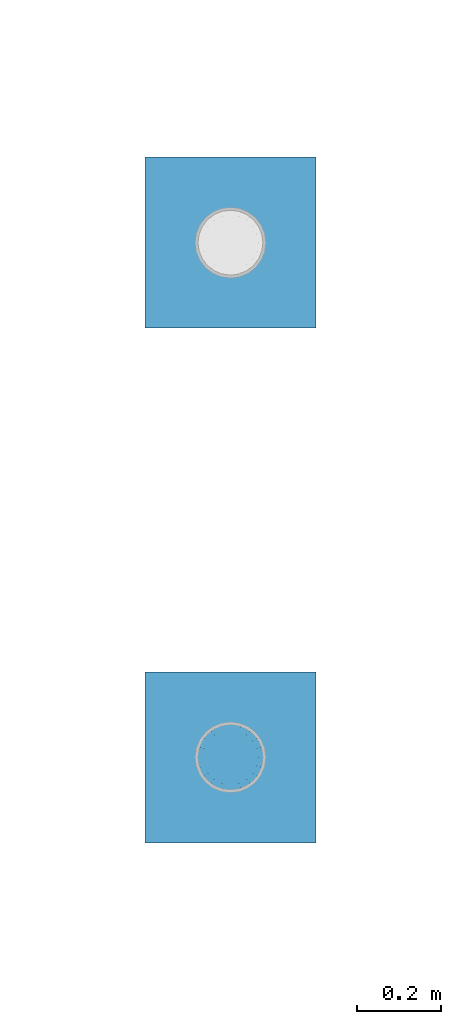
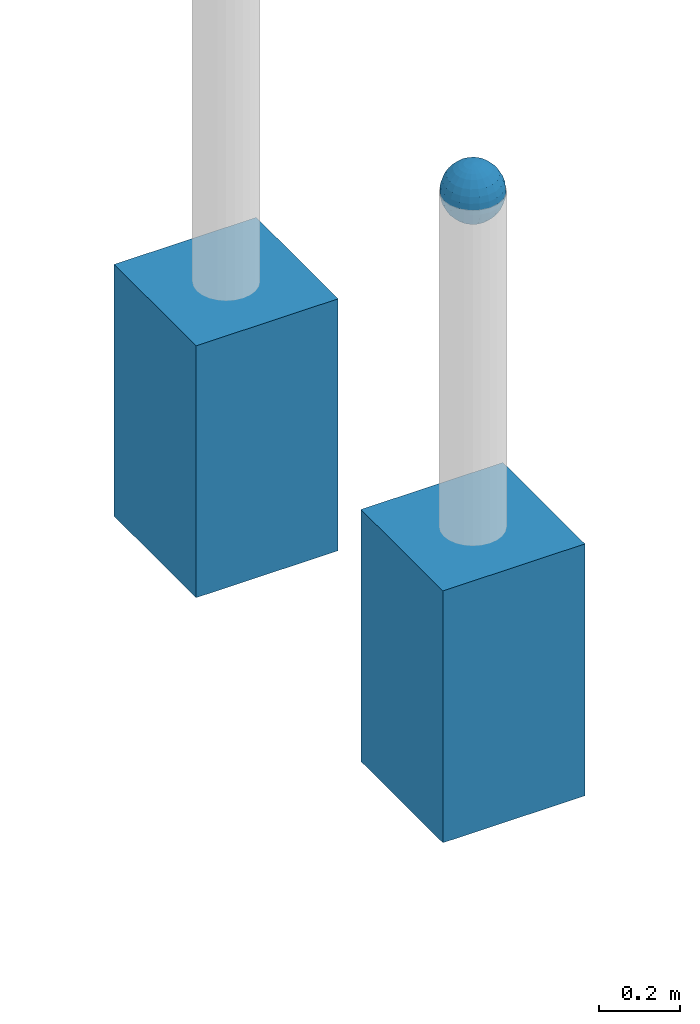
# One storey, part 1612 of 3843: 3 columns, 3 elements without a shape of their own.
"""IFC2X3 building model written with IfcOpenShell, lengths in millimetres."""

from ifc_helpers import new_model, si_unit, frame, origin_with_axes, place, context, subcontext, project, spatial, faceted_brep, material, type_object, element, aggregate, save


model = new_model("IFC2X3")

# Units and contexts
model_context = context("Model", 3, precision=1e-05, world=origin_with_axes())
body_context = subcontext(model_context, "Body", "Model", "MODEL_VIEW")
ifc_project = project(units=[si_unit("LENGTHUNIT", "METRE", prefix="MILLI"), si_unit("AREAUNIT", "SQUARE_METRE"), si_unit("VOLUMEUNIT", "CUBIC_METRE"), si_unit("MASSUNIT", "GRAM", prefix="KILO"), si_unit("TIMEUNIT", "SECOND"), si_unit("PLANEANGLEUNIT", "RADIAN"), si_unit("SOLIDANGLEUNIT", "STERADIAN"), si_unit("THERMODYNAMICTEMPERATUREUNIT", "DEGREE_CELSIUS"), si_unit("LUMINOUSINTENSITYUNIT", "LUMEN")], contexts=[model_context])

# Site, building, storey
site_placement = place(None, origin_with_axes())
site = spatial("IfcSite", under=ifc_project, at=site_placement, CompositionType="ELEMENT")
building_placement = place(site_placement, origin_with_axes())
building = spatial("IfcBuilding", under=site, at=building_placement, Name="Undefined", CompositionType="ELEMENT")
storey_placement = place(building_placement, origin_with_axes())
storey = spatial("IfcBuildingStorey", under=building, at=storey_placement, Name="Undefined", CompositionType="ELEMENT", Elevation=0.0)

# Assembly, column
assembly_1_placement = place(storey_placement, origin_with_axes())
assembly_1 = element("IfcElementAssembly", 1, at=assembly_1_placement, inside=storey, Name="CONC_COL.", AssemblyPlace="NOTDEFINED", PredefinedType="REINFORCEMENT_UNIT")
ifc_material_1 = material(Name="CONCRETE/3000")
column_type_1 = type_object("IfcColumnType", PredefinedType="NOTDEFINED")
column_1_placement = place(assembly_1_placement, frame((90265.7801817656, 12035.795690304, 29718.0), z_axis=(-1.0, 0.0, 0.0), x_axis=(0.0, 0.0, 1.0)))
column_1 = element("IfcColumn", 2, at=column_1_placement, type_object=column_type_1, material=ifc_material_1, Name="CONC_COL.", context=body_context, shape_type="Brep", body=[
    faceted_brep([(0.0, 203.199999999997, -203.200000000001), (0.0, 203.199999999997, 203.200000000001), (762.0, 203.199999999997, 203.200000000001), (762.0, 203.199999999997, -203.200000000001), (0.0, -203.199999999997, 203.200000000001), (762.0, -203.199999999997, 203.200000000001), (0.0, -203.199999999997, -203.200000000001), (762.0, -203.199999999997, -203.200000000001)], [[[0, 1, 2, 3]], [[1, 4, 5, 2]], [[4, 6, 7, 5]], [[6, 0, 3, 7]], [[5, 7, 3, 2]], [[6, 4, 1, 0]]]),
])
aggregate(assembly_1, [column_1])

assembly_2_placement = place(storey_placement, origin_with_axes())
assembly_2 = element("IfcElementAssembly", 3, at=assembly_2_placement, inside=storey, Name="CONC_COL.", AssemblyPlace="NOTDEFINED", PredefinedType="REINFORCEMENT_UNIT")
column_2_placement = place(assembly_2_placement, frame((90265.7801817656, 13258.3985345423, 29718.0), z_axis=(-1.0, 0.0, 0.0), x_axis=(0.0, 0.0, 1.0)))
column_2 = element("IfcColumn", 4, at=column_2_placement, type_object=column_type_1, material=ifc_material_1, Name="CONC_COL.", context=body_context, shape_type="Brep", body=[
    faceted_brep([(0.0, 203.199999999997, -203.200000000001), (0.0, 203.199999999997, 203.200000000001), (762.0, 203.199999999997, 203.200000000001), (762.0, 203.199999999997, -203.200000000001), (0.0, -203.199999999997, 203.200000000001), (762.0, -203.199999999997, 203.200000000001), (0.0, -203.199999999997, -203.200000000001), (762.0, -203.199999999997, -203.200000000001)], [[[0, 1, 2, 3]], [[1, 4, 5, 2]], [[4, 6, 7, 5]], [[6, 0, 3, 7]], [[5, 7, 3, 2]], [[6, 4, 1, 0]]]),
])
aggregate(assembly_2, [column_2])

assembly_3_placement = place(storey_placement, origin_with_axes())
assembly_3 = element("IfcElementAssembly", 5, at=assembly_3_placement, inside=storey, Name="CONC. FILL", AssemblyPlace="NOTDEFINED", PredefinedType="REINFORCEMENT_UNIT")
ifc_material_2 = material(Name="CONCRETE/1500")
column_type_2 = type_object("IfcColumnType", PredefinedType="NOTDEFINED")
column_3_placement = place(assembly_3_placement, frame((90265.7801817655, 12035.795690304, 31411.8625), z_axis=(-1.0, 0.0, 0.0), x_axis=(0.0, 0.0, 1.0)))
column_3 = element("IfcColumn", 6, at=column_3_placement, type_object=column_type_2, material=ifc_material_2, Name="CONC. FILL", context=body_context, shape_type="Brep", body=[
    faceted_brep([(0.0, 0.0, 2.0), (0.0, -0.619999999995343, 1.89999999999964), (3.36549999999988, -7.1422259999963, 21.9814139999999), (3.36549999999988, 0.0, 23.1139999999996), (0.0, -1.17999999999302, 1.6200000000008), (3.36549999999988, -13.5910319999966, 18.6992260000006), (0.0, -1.61999999999534, 1.18000000000029), (3.36549999999988, -18.699225999997, 13.5910320000003), (0.0, -1.89999999999418, 0.6200000000008), (3.36549999999988, -21.9814139999944, 7.14222599999994), (0.0, -2.0, 0.0), (3.36549999999988, -23.1140000000014, 0.0), (0.0, -1.89999999999418, -0.6200000000008), (3.36549999999988, -21.9814139999944, -7.14222599999994), (0.0, -1.61999999999534, -1.18000000000029), (3.36549999999988, -18.699225999997, -13.5910320000003), (0.0, -1.17999999999302, -1.6200000000008), (3.36549999999988, -13.5910319999966, -18.6992260000006), (0.0, -0.619999999995343, -1.89999999999964), (3.36549999999988, -7.1422259999963, -21.9814139999999), (0.0, 0.0, -2.0), (3.36549999999988, 0.0, -23.1139999999996), (0.0, 0.619999999995343, -1.89999999999964), (3.36549999999988, 7.1422259999963, -21.9814139999999), (0.0, 1.17999999999302, -1.6200000000008), (3.36549999999988, 13.5910319999966, -18.6992260000006), (0.0, 1.61999999999534, -1.18000000000029), (3.36549999999988, 18.699225999997, -13.5910320000003), (0.0, 1.89999999999418, -0.6200000000008), (3.36549999999988, 21.9814139999944, -7.14222599999994), (0.0, 2.0, 0.0), (3.36549999999988, 23.1140000000014, 0.0), (0.0, 1.89999999999418, 0.6200000000008), (3.36549999999988, 21.9814139999944, 7.14222599999994), (0.0, 1.61999999999534, 1.18000000000029), (3.36549999999988, 18.699225999997, 13.5910320000003), (0.0, 1.17999999999302, 1.6200000000008), (3.36549999999988, 13.5910319999966, 18.6992260000006), (0.0, 0.619999999995343, 1.89999999999964), (3.36549999999988, 7.1422259999963, 21.9814139999999), (8.41374999999971, -11.1214661999984, 34.2282018000005), (8.41374999999971, 0.0, 35.9917999999998), (8.41374999999971, -21.1631784000056, 29.1173662000001), (8.41374999999971, -29.1173661999928, 21.1631784000001), (8.41374999999971, -34.2282017999969, 11.1214662000002), (8.41374999999971, -35.9918000000034, 0.0), (8.41374999999971, -34.2282017999969, -11.1214662000002), (8.41374999999971, -29.1173661999928, -21.1631784000001), (8.41374999999971, -21.1631784000056, -29.1173662000001), (8.41374999999971, -11.1214661999984, -34.2282018000005), (8.41374999999971, 0.0, -35.9917999999998), (8.41374999999971, 11.1214661999984, -34.2282018000005), (8.41374999999971, 21.1631784000056, -29.1173662000001), (8.41374999999971, 29.1173661999928, -21.1631784000001), (8.41374999999971, 34.2282017999969, -11.1214662000002), (8.41374999999971, 35.9918000000034, 0.0), (8.41374999999971, 34.2282017999969, 11.1214662000002), (8.41374999999971, 29.1173661999928, 21.1631784000001), (8.41374999999971, 21.1631784000056, 29.1173662000001), (8.41374999999971, 11.1214661999984, 34.2282018000005), (16.8274999999994, -15.3047700000025, 47.1030300000002), (16.8274999999994, 0.0, 49.5300000000007), (16.8274999999994, -29.1236400000053, 40.0697700000001), (16.8274999999994, -40.0697700000019, 29.1236399999998), (16.8274999999994, -47.1030299999984, 15.3047700000006), (16.8274999999994, -49.5299999999988, 0.0), (16.8274999999994, -47.1030299999984, -15.3047700000006), (16.8274999999994, -40.0697700000019, -29.1236399999998), (16.8274999999994, -29.1236400000053, -40.0697700000001), (16.8274999999994, -15.3047700000025, -47.1030300000002), (16.8274999999994, 0.0, -49.5300000000007), (16.8274999999994, 15.3047700000025, -47.1030300000002), (16.8274999999994, 29.1236400000053, -40.0697700000001), (16.8274999999994, 40.0697700000019, -29.1236399999998), (16.8274999999994, 47.1030299999984, -15.3047700000006), (16.8274999999994, 49.5299999999988, 0.0), (16.8274999999994, 47.1030299999984, 15.3047700000006), (16.8274999999994, 40.0697700000019, 29.1236399999998), (16.8274999999994, 29.1236400000053, 40.0697700000001), (16.8274999999994, 15.3047700000025, 47.1030300000002), (33.6549999999988, -20.4063599999936, 62.8040400000009), (33.6549999999988, 0.0, 66.0400000000009), (33.6549999999988, -38.831520000007, 53.4263599999995), (33.6549999999988, -53.4263599999977, 38.8315199999997), (33.6549999999988, -62.8040400000027, 20.4063600000009), (33.6549999999988, -66.0399999999936, 0.0), (33.6549999999988, -62.8040400000027, -20.4063600000009), (33.6549999999988, -53.4263599999977, -38.8315199999997), (33.6549999999988, -38.831520000007, -53.4263599999995), (33.6549999999988, -20.4063599999936, -62.8040400000009), (33.6549999999988, 0.0, -66.0400000000009), (33.6549999999988, 20.4063599999936, -62.8040400000009), (33.6549999999988, 38.831520000007, -53.4263599999995), (33.6549999999988, 53.4263599999977, -38.8315199999997), (33.6549999999988, 62.8040400000027, -20.4063600000009), (33.6549999999988, 66.0399999999936, 0.0), (33.6549999999988, 62.8040400000027, 20.4063600000009), (33.6549999999988, 53.4263599999977, 38.8315199999997), (33.6549999999988, 38.831520000007, 53.4263599999995), (33.6549999999988, 20.4063599999936, 62.8040400000009), (50.4824999999983, -23.3907901500061, 71.9891308499991), (50.4824999999983, 0.0, 75.6983500000006), (50.4824999999983, -44.5106298000028, 61.23996515), (50.4824999999983, -61.2399651500018, 44.5106297999992), (50.4824999999983, -71.9891308499937, 23.3907901500006), (50.4824999999983, -75.698350000006, 0.0), (50.4824999999983, -71.9891308499937, -23.3907901500006), (50.4824999999983, -61.2399651500018, -44.5106297999992), (50.4824999999983, -44.5106298000028, -61.23996515), (50.4824999999983, -23.3907901500061, -71.9891308499991), (50.4824999999983, 0.0, -75.6983500000006), (50.4824999999983, 23.3907901500061, -71.9891308499991), (50.4824999999983, 44.5106298000028, -61.23996515), (50.4824999999983, 61.2399651500018, -44.5106297999992), (50.4824999999983, 71.9891308499937, -23.3907901500006), (50.4824999999983, 75.698350000006, 0.0), (50.4824999999983, 71.9891308499937, 23.3907901500006), (50.4824999999983, 61.2399651500018, 44.5106297999992), (50.4824999999983, 44.5106298000028, 61.23996515), (50.4824999999983, 23.3907901500061, 71.9891308499991), (67.3099999999977, -24.9977910000016, 76.9349490000004), (67.3099999999977, 0.0, 80.8989999999994), (67.3099999999977, -47.5686120000028, 65.4472910000004), (67.3099999999977, -65.447291000004, 47.5686119999991), (67.3099999999977, -76.9349490000022, 24.9977909999998), (67.3099999999977, -80.8990000000049, 0.0), (67.3099999999977, -76.9349490000022, -24.9977909999998), (67.3099999999977, -65.447291000004, -47.5686119999991), (67.3099999999977, -47.5686120000028, -65.4472910000004), (67.3099999999977, -24.9977910000016, -76.9349490000004), (67.3099999999977, 0.0, -80.8989999999994), (67.3099999999977, 24.9977910000016, -76.9349490000004), (67.3099999999977, 47.5686120000028, -65.4472910000004), (67.3099999999977, 65.447291000004, -47.5686119999991), (67.3099999999977, 76.9349490000022, -24.9977909999998), (67.3099999999977, 80.8990000000049, 0.0), (67.3099999999977, 76.9349490000022, 24.9977909999998), (67.3099999999977, 65.447291000004, 47.5686119999991), (67.3099999999977, 47.5686120000028, 65.4472910000004), (67.3099999999977, 24.9977910000016, 76.9349490000004), (84.1374999999935, -25.5079499999993, 78.5050499999998), (84.1374999999935, 0.0, 82.5499999999993), (84.1374999999935, -48.5393999999942, 66.7829500000007), (84.1374999999935, -66.7829499999934, 48.5393999999997), (84.1374999999935, -78.505050000007, 25.5079499999993), (84.1374999999935, -82.5500000000029, 0.0), (84.1374999999935, -78.505050000007, -25.5079499999993), (84.1374999999935, -66.7829499999934, -48.5393999999997), (84.1374999999935, -48.5393999999942, -66.7829500000007), (84.1374999999935, -25.5079499999993, -78.5050499999998), (84.1374999999935, 0.0, -82.5499999999993), (84.1374999999935, 25.5079499999993, -78.5050499999998), (84.1374999999935, 48.5393999999942, -66.7829500000007), (84.1374999999935, 66.7829499999934, -48.5393999999997), (84.1374999999935, 78.505050000007, -25.5079499999993), (84.1374999999935, 82.5500000000029, 0.0), (84.1374999999935, 78.505050000007, 25.5079499999993), (84.1374999999935, 66.7829499999934, 48.5393999999997), (84.1374999999935, 48.5393999999942, 66.7829500000007), (84.1374999999935, 25.5079499999993, 78.5050499999998), (100.964999999993, -24.9977910000016, 76.9349490000004), (100.964999999993, 0.0, 80.8989999999994), (100.964999999993, -47.5686120000028, 65.4472910000004), (100.964999999993, -65.447291000004, 47.5686119999991), (100.964999999993, -76.9349490000022, 24.9977909999998), (100.964999999993, -80.8990000000049, 0.0), (100.964999999993, -76.9349490000022, -24.9977909999998), (100.964999999993, -65.447291000004, -47.5686119999991), (100.964999999993, -47.5686120000028, -65.4472910000004), (100.964999999993, -24.9977910000016, -76.9349490000004), (100.964999999993, 0.0, -80.8989999999994), (100.964999999993, 24.9977910000016, -76.9349490000004), (100.964999999993, 47.5686120000028, -65.4472910000004), (100.964999999993, 65.447291000004, -47.5686119999991), (100.964999999993, 76.9349490000022, -24.9977909999998), (100.964999999993, 80.8990000000049, 0.0), (100.964999999993, 76.9349490000022, 24.9977909999998), (100.964999999993, 65.447291000004, 47.5686119999991), (100.964999999993, 47.5686120000028, 65.4472910000004), (100.964999999993, 24.9977910000016, 76.9349490000004), (117.792499999992, -23.3907901500061, 71.9891308499991), (117.792499999992, 0.0, 75.6983500000006), (117.792499999992, -44.5106298000028, 61.23996515), (117.792499999992, -61.2399651500018, 44.5106297999992), (117.792499999992, -71.9891308499937, 23.3907901500006), (117.792499999992, -75.698350000006, 0.0), (117.792499999992, -71.9891308499937, -23.3907901500006), (117.792499999992, -61.2399651500018, -44.5106297999992), (117.792499999992, -44.5106298000028, -61.23996515), (117.792499999992, -23.3907901500061, -71.9891308499991), (117.792499999992, 0.0, -75.6983500000006), (117.792499999992, 23.3907901500061, -71.9891308499991), (117.792499999992, 44.5106298000028, -61.23996515), (117.792499999992, 61.2399651500018, -44.5106297999992), (117.792499999992, 71.9891308499937, -23.3907901500006), (117.792499999992, 75.698350000006, 0.0), (117.792499999992, 71.9891308499937, 23.3907901500006), (117.792499999992, 61.2399651500018, 44.5106297999992), (117.792499999992, 44.5106298000028, 61.23996515), (117.792499999992, 23.3907901500061, 71.9891308499991), (134.619999999992, -20.4063599999936, 62.8040400000009), (134.619999999992, 0.0, 66.0400000000009), (134.619999999992, -38.831520000007, 53.4263599999995), (134.619999999992, -53.4263599999977, 38.8315199999997), (134.619999999992, -62.8040400000027, 20.4063600000009), (134.619999999992, -66.0399999999936, 0.0), (134.619999999992, -62.8040400000027, -20.4063600000009), (134.619999999992, -53.4263599999977, -38.8315199999997), (134.619999999992, -38.831520000007, -53.4263599999995), (134.619999999992, -20.4063599999936, -62.8040400000009), (134.619999999992, 0.0, -66.0400000000009), (134.619999999992, 20.4063599999936, -62.8040400000009), (134.619999999992, 38.831520000007, -53.4263599999995), (134.619999999992, 53.4263599999977, -38.8315199999997), (134.619999999992, 62.8040400000027, -20.4063600000009), (134.619999999992, 66.0399999999936, 0.0), (134.619999999992, 62.8040400000027, 20.4063600000009), (134.619999999992, 53.4263599999977, 38.8315199999997), (134.619999999992, 38.831520000007, 53.4263599999995), (134.619999999992, 20.4063599999936, 62.8040400000009), (151.447499999991, -15.3047700000025, 47.1030300000002), (151.447499999991, 0.0, 49.5300000000007), (151.447499999991, -29.1236400000053, 40.0697700000001), (151.447499999991, -40.0697700000019, 29.1236399999998), (151.447499999991, -47.1030299999984, 15.3047700000006), (151.447499999991, -49.5299999999988, 0.0), (151.447499999991, -47.1030299999984, -15.3047700000006), (151.447499999991, -40.0697700000019, -29.1236399999998), (151.447499999991, -29.1236400000053, -40.0697700000001), (151.447499999991, -15.3047700000025, -47.1030300000002), (151.447499999991, 0.0, -49.5300000000007), (151.447499999991, 15.3047700000025, -47.1030300000002), (151.447499999991, 29.1236400000053, -40.0697700000001), (151.447499999991, 40.0697700000019, -29.1236399999998), (151.447499999991, 47.1030299999984, -15.3047700000006), (151.447499999991, 49.5299999999988, 0.0), (151.447499999991, 47.1030299999984, 15.3047700000006), (151.447499999991, 40.0697700000019, 29.1236399999998), (151.447499999991, 29.1236400000053, 40.0697700000001), (151.447499999991, 15.3047700000025, 47.1030300000002), (159.861249999991, -11.1214661999984, 34.2282018000005), (159.861249999991, 0.0, 35.9917999999998), (159.861249999991, -21.1631784000056, 29.1173662000001), (159.861249999991, -29.1173661999928, 21.1631784000001), (159.861249999991, -34.2282017999969, 11.1214662000002), (159.861249999991, -35.9918000000034, 0.0), (159.861249999991, -34.2282017999969, -11.1214662000002), (159.861249999991, -29.1173661999928, -21.1631784000001), (159.861249999991, -21.1631784000056, -29.1173662000001), (159.861249999991, -11.1214661999984, -34.2282018000005), (159.861249999991, 0.0, -35.9917999999998), (159.861249999991, 11.1214661999984, -34.2282018000005), (159.861249999991, 21.1631784000056, -29.1173662000001), (159.861249999991, 29.1173661999928, -21.1631784000001), (159.861249999991, 34.2282017999969, -11.1214662000002), (159.861249999991, 35.9918000000034, 0.0), (159.861249999991, 34.2282017999969, 11.1214662000002), (159.861249999991, 29.1173661999928, 21.1631784000001), (159.861249999991, 21.1631784000056, 29.1173662000001), (159.861249999991, 11.1214661999984, 34.2282018000005), (164.909499999991, -7.1422259999963, 21.9814139999999), (164.909499999991, 0.0, 23.1139999999996), (164.909499999991, -13.5910319999966, 18.6992260000006), (164.909499999991, -18.699225999997, 13.5910320000003), (164.909499999991, -21.9814139999944, 7.14222599999994), (164.909499999991, -23.1140000000014, 0.0), (164.909499999991, -21.9814139999944, -7.14222599999994), (164.909499999991, -18.699225999997, -13.5910320000003), (164.909499999991, -13.5910319999966, -18.6992260000006), (164.909499999991, -7.1422259999963, -21.9814139999999), (164.909499999991, 0.0, -23.1139999999996), (164.909499999991, 7.1422259999963, -21.9814139999999), (164.909499999991, 13.5910319999966, -18.6992260000006), (164.909499999991, 18.699225999997, -13.5910320000003), (164.909499999991, 21.9814139999944, -7.14222599999994), (164.909499999991, 23.1140000000014, 0.0), (164.909499999991, 21.9814139999944, 7.14222599999994), (164.909499999991, 18.699225999997, 13.5910320000003), (164.909499999991, 13.5910319999966, 18.6992260000006), (164.909499999991, 7.1422259999963, 21.9814139999999), (168.274999999991, -0.619999999995343, 1.89999999999964), (168.274999999991, 0.0, 2.0), (168.274999999991, -1.17999999999302, 1.6200000000008), (168.274999999991, -1.61999999999534, 1.18000000000029), (168.274999999991, -1.89999999999418, 0.6200000000008), (168.274999999991, -2.0, 0.0), (168.274999999991, -1.89999999999418, -0.6200000000008), (168.274999999991, -1.61999999999534, -1.18000000000029), (168.274999999991, -1.17999999999302, -1.6200000000008), (168.274999999991, -0.619999999995343, -1.89999999999964), (168.274999999991, 0.0, -2.0), (168.274999999991, 0.619999999995343, -1.89999999999964), (168.274999999991, 1.17999999999302, -1.6200000000008), (168.274999999991, 1.61999999999534, -1.18000000000029), (168.274999999991, 1.89999999999418, -0.6200000000008), (168.274999999991, 2.0, 0.0), (168.274999999991, 1.89999999999418, 0.6200000000008), (168.274999999991, 1.61999999999534, 1.18000000000029), (168.274999999991, 1.17999999999302, 1.6200000000008), (168.274999999991, 0.619999999995343, 1.89999999999964)], [[[0, 1, 2, 3]], [[1, 4, 5, 2]], [[4, 6, 7, 5]], [[6, 8, 9, 7]], [[8, 10, 11, 9]], [[10, 12, 13, 11]], [[12, 14, 15, 13]], [[14, 16, 17, 15]], [[16, 18, 19, 17]], [[18, 20, 21, 19]], [[20, 22, 23, 21]], [[22, 24, 25, 23]], [[24, 26, 27, 25]], [[26, 28, 29, 27]], [[28, 30, 31, 29]], [[30, 32, 33, 31]], [[32, 34, 35, 33]], [[34, 36, 37, 35]], [[36, 38, 39, 37]], [[38, 0, 3, 39]], [[38, 36, 34, 32, 30, 28, 26, 24, 22, 20, 18, 16, 14, 12, 10, 8, 6, 4, 1, 0]], [[3, 2, 40, 41]], [[2, 5, 42, 40]], [[5, 7, 43, 42]], [[7, 9, 44, 43]], [[9, 11, 45, 44]], [[11, 13, 46, 45]], [[13, 15, 47, 46]], [[15, 17, 48, 47]], [[17, 19, 49, 48]], [[19, 21, 50, 49]], [[21, 23, 51, 50]], [[23, 25, 52, 51]], [[25, 27, 53, 52]], [[27, 29, 54, 53]], [[29, 31, 55, 54]], [[31, 33, 56, 55]], [[33, 35, 57, 56]], [[35, 37, 58, 57]], [[37, 39, 59, 58]], [[39, 3, 41, 59]], [[41, 40, 60, 61]], [[40, 42, 62, 60]], [[42, 43, 63, 62]], [[43, 44, 64, 63]], [[44, 45, 65, 64]], [[45, 46, 66, 65]], [[46, 47, 67, 66]], [[47, 48, 68, 67]], [[48, 49, 69, 68]], [[49, 50, 70, 69]], [[50, 51, 71, 70]], [[51, 52, 72, 71]], [[52, 53, 73, 72]], [[53, 54, 74, 73]], [[54, 55, 75, 74]], [[55, 56, 76, 75]], [[56, 57, 77, 76]], [[57, 58, 78, 77]], [[58, 59, 79, 78]], [[59, 41, 61, 79]], [[61, 60, 80, 81]], [[60, 62, 82, 80]], [[62, 63, 83, 82]], [[63, 64, 84, 83]], [[64, 65, 85, 84]], [[65, 66, 86, 85]], [[66, 67, 87, 86]], [[67, 68, 88, 87]], [[68, 69, 89, 88]], [[69, 70, 90, 89]], [[70, 71, 91, 90]], [[71, 72, 92, 91]], [[72, 73, 93, 92]], [[73, 74, 94, 93]], [[74, 75, 95, 94]], [[75, 76, 96, 95]], [[76, 77, 97, 96]], [[77, 78, 98, 97]], [[78, 79, 99, 98]], [[79, 61, 81, 99]], [[81, 80, 100, 101]], [[80, 82, 102, 100]], [[82, 83, 103, 102]], [[83, 84, 104, 103]], [[84, 85, 105, 104]], [[85, 86, 106, 105]], [[86, 87, 107, 106]], [[87, 88, 108, 107]], [[88, 89, 109, 108]], [[89, 90, 110, 109]], [[90, 91, 111, 110]], [[91, 92, 112, 111]], [[92, 93, 113, 112]], [[93, 94, 114, 113]], [[94, 95, 115, 114]], [[95, 96, 116, 115]], [[96, 97, 117, 116]], [[97, 98, 118, 117]], [[98, 99, 119, 118]], [[99, 81, 101, 119]], [[101, 100, 120, 121]], [[100, 102, 122, 120]], [[102, 103, 123, 122]], [[103, 104, 124, 123]], [[104, 105, 125, 124]], [[105, 106, 126, 125]], [[106, 107, 127, 126]], [[107, 108, 128, 127]], [[108, 109, 129, 128]], [[109, 110, 130, 129]], [[110, 111, 131, 130]], [[111, 112, 132, 131]], [[112, 113, 133, 132]], [[113, 114, 134, 133]], [[114, 115, 135, 134]], [[115, 116, 136, 135]], [[116, 117, 137, 136]], [[117, 118, 138, 137]], [[118, 119, 139, 138]], [[119, 101, 121, 139]], [[121, 120, 140, 141]], [[120, 122, 142, 140]], [[122, 123, 143, 142]], [[123, 124, 144, 143]], [[124, 125, 145, 144]], [[125, 126, 146, 145]], [[126, 127, 147, 146]], [[127, 128, 148, 147]], [[128, 129, 149, 148]], [[129, 130, 150, 149]], [[130, 131, 151, 150]], [[131, 132, 152, 151]], [[132, 133, 153, 152]], [[133, 134, 154, 153]], [[134, 135, 155, 154]], [[135, 136, 156, 155]], [[136, 137, 157, 156]], [[137, 138, 158, 157]], [[138, 139, 159, 158]], [[139, 121, 141, 159]], [[141, 140, 160, 161]], [[140, 142, 162, 160]], [[142, 143, 163, 162]], [[143, 144, 164, 163]], [[144, 145, 165, 164]], [[145, 146, 166, 165]], [[146, 147, 167, 166]], [[147, 148, 168, 167]], [[148, 149, 169, 168]], [[149, 150, 170, 169]], [[150, 151, 171, 170]], [[151, 152, 172, 171]], [[152, 153, 173, 172]], [[153, 154, 174, 173]], [[154, 155, 175, 174]], [[155, 156, 176, 175]], [[156, 157, 177, 176]], [[157, 158, 178, 177]], [[158, 159, 179, 178]], [[159, 141, 161, 179]], [[161, 160, 180, 181]], [[160, 162, 182, 180]], [[162, 163, 183, 182]], [[163, 164, 184, 183]], [[164, 165, 185, 184]], [[165, 166, 186, 185]], [[166, 167, 187, 186]], [[167, 168, 188, 187]], [[168, 169, 189, 188]], [[169, 170, 190, 189]], [[170, 171, 191, 190]], [[171, 172, 192, 191]], [[172, 173, 193, 192]], [[173, 174, 194, 193]], [[174, 175, 195, 194]], [[175, 176, 196, 195]], [[176, 177, 197, 196]], [[177, 178, 198, 197]], [[178, 179, 199, 198]], [[179, 161, 181, 199]], [[181, 180, 200, 201]], [[180, 182, 202, 200]], [[182, 183, 203, 202]], [[183, 184, 204, 203]], [[184, 185, 205, 204]], [[185, 186, 206, 205]], [[186, 187, 207, 206]], [[187, 188, 208, 207]], [[188, 189, 209, 208]], [[189, 190, 210, 209]], [[190, 191, 211, 210]], [[191, 192, 212, 211]], [[192, 193, 213, 212]], [[193, 194, 214, 213]], [[194, 195, 215, 214]], [[195, 196, 216, 215]], [[196, 197, 217, 216]], [[197, 198, 218, 217]], [[198, 199, 219, 218]], [[199, 181, 201, 219]], [[201, 200, 220, 221]], [[200, 202, 222, 220]], [[202, 203, 223, 222]], [[203, 204, 224, 223]], [[204, 205, 225, 224]], [[205, 206, 226, 225]], [[206, 207, 227, 226]], [[207, 208, 228, 227]], [[208, 209, 229, 228]], [[209, 210, 230, 229]], [[210, 211, 231, 230]], [[211, 212, 232, 231]], [[212, 213, 233, 232]], [[213, 214, 234, 233]], [[214, 215, 235, 234]], [[215, 216, 236, 235]], [[216, 217, 237, 236]], [[217, 218, 238, 237]], [[218, 219, 239, 238]], [[219, 201, 221, 239]], [[221, 220, 240, 241]], [[220, 222, 242, 240]], [[222, 223, 243, 242]], [[223, 224, 244, 243]], [[224, 225, 245, 244]], [[225, 226, 246, 245]], [[226, 227, 247, 246]], [[227, 228, 248, 247]], [[228, 229, 249, 248]], [[229, 230, 250, 249]], [[230, 231, 251, 250]], [[231, 232, 252, 251]], [[232, 233, 253, 252]], [[233, 234, 254, 253]], [[234, 235, 255, 254]], [[235, 236, 256, 255]], [[236, 237, 257, 256]], [[237, 238, 258, 257]], [[238, 239, 259, 258]], [[239, 221, 241, 259]], [[241, 240, 260, 261]], [[240, 242, 262, 260]], [[242, 243, 263, 262]], [[243, 244, 264, 263]], [[244, 245, 265, 264]], [[245, 246, 266, 265]], [[246, 247, 267, 266]], [[247, 248, 268, 267]], [[248, 249, 269, 268]], [[249, 250, 270, 269]], [[250, 251, 271, 270]], [[251, 252, 272, 271]], [[252, 253, 273, 272]], [[253, 254, 274, 273]], [[254, 255, 275, 274]], [[255, 256, 276, 275]], [[256, 257, 277, 276]], [[257, 258, 278, 277]], [[258, 259, 279, 278]], [[259, 241, 261, 279]], [[261, 260, 280, 281]], [[260, 262, 282, 280]], [[262, 263, 283, 282]], [[263, 264, 284, 283]], [[264, 265, 285, 284]], [[265, 266, 286, 285]], [[266, 267, 287, 286]], [[267, 268, 288, 287]], [[268, 269, 289, 288]], [[269, 270, 290, 289]], [[270, 271, 291, 290]], [[271, 272, 292, 291]], [[272, 273, 293, 292]], [[273, 274, 294, 293]], [[274, 275, 295, 294]], [[275, 276, 296, 295]], [[276, 277, 297, 296]], [[277, 278, 298, 297]], [[278, 279, 299, 298]], [[279, 261, 281, 299]], [[282, 283, 284, 285, 286, 287, 288, 289, 290, 291, 292, 293, 294, 295, 296, 297, 298, 299, 281, 280]]]),
])
aggregate(assembly_3, [column_3])

save(model, "model.ifc")
